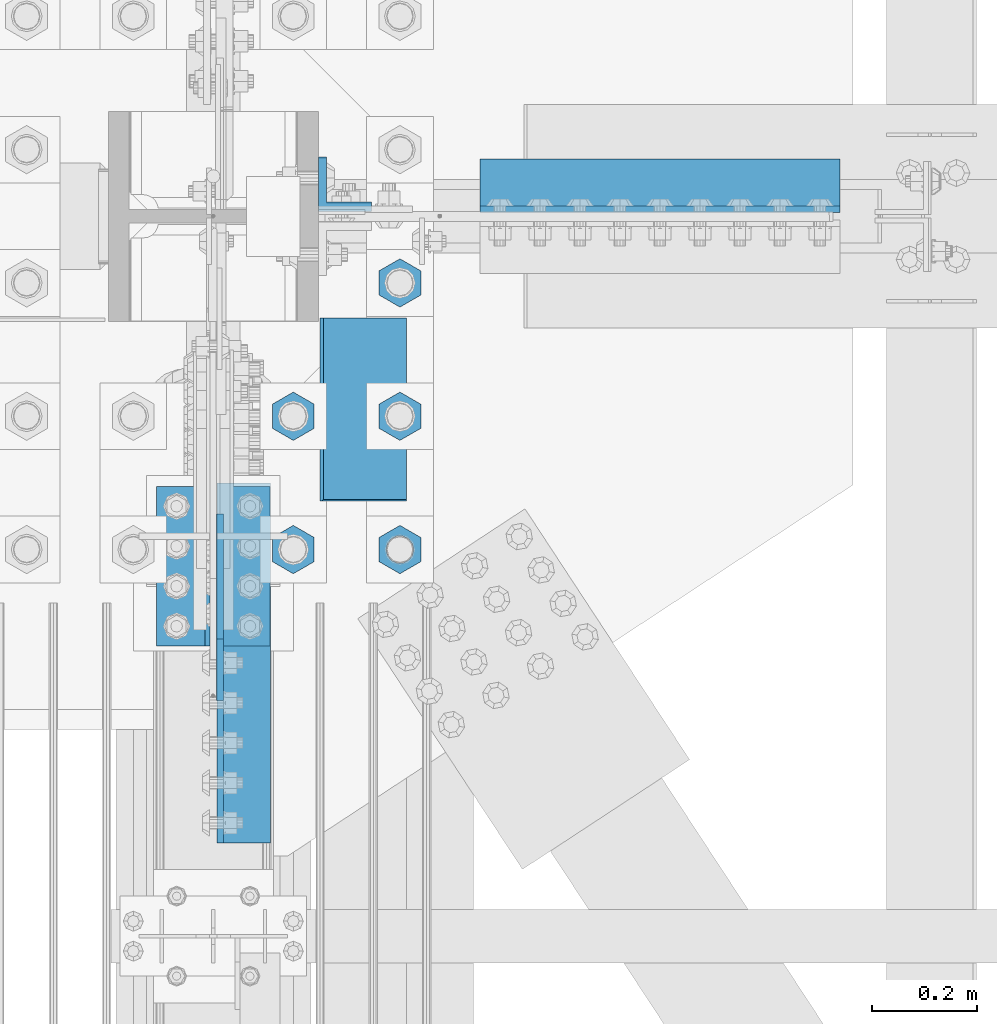
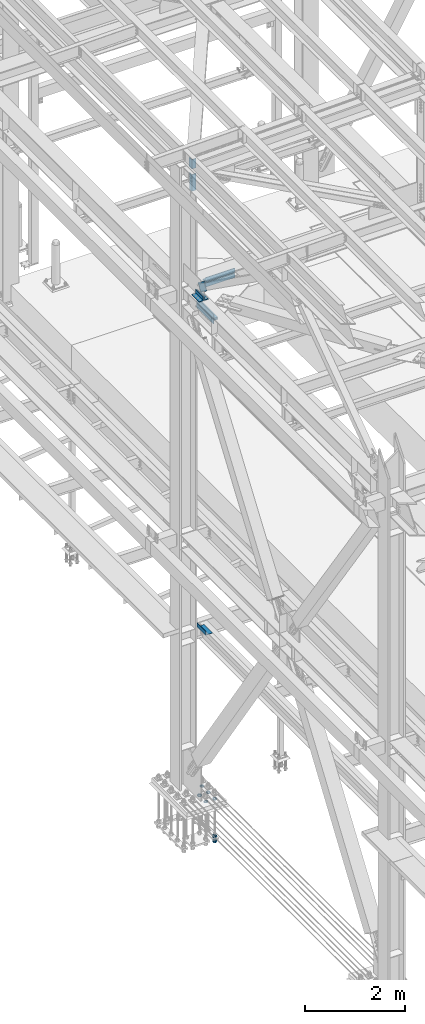
# One storey, part 2384 of 3843: 16 beams, 1 member, 8 elements without a shape of their own.
"""IFC2X3 building model written with IfcOpenShell, lengths in millimetres."""

import ifcopenshell
import ifcopenshell.guid

model = None  # the IFC model being written
_history = None  # IfcOwnerHistory: only IFC2X3 demands one
_inside = {}  # id of a spatial element -> (the spatial element, [elements in it])
_under = {}  # id of a project, library or spatial element -> (it, [spatial elements below it])
_declared = {}  # id of a project -> (the project, [libraries it declares])
_typed = {}  # id of a type object -> (the type object, [elements of that type])
_made_of = {}  # id of a material, layer set ... -> (it, [elements and type objects made of it])


def new_model(schema):
    """Start an empty IFC model of exactly this schema.

    Asked for "IFC4X3", IfcOpenShell would pick the latest addendum, in which some entities
    have other attributes; the version numbers below select the first issue.
    IFC2X3 requires an IfcOwnerHistory on every rooted entity: one is made here for all.
    """
    global model, _history
    if schema == "IFC4X3":
        model = ifcopenshell.file(schema_version=(4, 3, 0, 0))
    else:
        model = ifcopenshell.file(schema=schema)
    _inside.clear()
    _under.clear()
    _declared.clear()
    _typed.clear()
    _made_of.clear()
    _history = None
    if model.schema == "IFC2X3":
        org = make("IfcOrganization", Name="unknown")
        user = make(
            "IfcPersonAndOrganization",
            ThePerson=make("IfcPerson", FamilyName="unknown"),
            TheOrganization=org,
        )
        app = make(
            "IfcApplication",
            ApplicationDeveloper=org,
            Version="unknown",
            ApplicationFullName="unknown",
            ApplicationIdentifier="unknown",
        )
        _history = make(
            "IfcOwnerHistory",
            OwningUser=user,
            OwningApplication=app,
            ChangeAction="ADDED",
            CreationDate=0,
        )
    return model


def make(cls, **values):
    """One entity of the class cls with the attributes given. An attribute that is None is left unset."""
    return model.create_entity(
        cls, **{name: value for name, value in values.items() if value is not None}
    )


def rooted(cls, **values):
    """An entity with a GlobalId (a new one), such as an element, a storey or a relation."""
    return make(cls, GlobalId=ifcopenshell.guid.new(), OwnerHistory=_history, **values)


def si_unit(unit_type, name, prefix=None):
    """IfcSIUnit, for example si_unit("LENGTHUNIT", "METRE", prefix="MILLI")."""
    return make("IfcSIUnit", UnitType=unit_type, Prefix=prefix, Name=name)


def assignment(units):
    """IfcUnitAssignment: the units of a project."""
    return None if units is None else make("IfcUnitAssignment", Units=units)


def point(xyz):
    """IfcCartesianPoint."""
    return None if xyz is None else make("IfcCartesianPoint", Coordinates=xyz)


def direction(xyz):
    """IfcDirection."""
    return None if xyz is None else make("IfcDirection", DirectionRatios=xyz)


def frame(location, z_axis=None, x_axis=None):
    """IfcAxis2Placement3D, a coordinate frame: its origin and axes. An axis left out is left unset."""
    return make(
        "IfcAxis2Placement3D",
        Location=point(location),
        Axis=direction(z_axis),
        RefDirection=direction(x_axis),
    )


def origin_with_axes():
    """The frame at (0, 0, 0) with the z axis (0, 0, 1) and the x axis (1, 0, 0) written out."""
    return frame((0.0, 0.0, 0.0), z_axis=(0.0, 0.0, 1.0), x_axis=(1.0, 0.0, 0.0))


def place(relative_to, where):
    """IfcLocalPlacement: puts the frame where relative to a parent placement (None: the world)."""
    return make(
        "IfcLocalPlacement", PlacementRelTo=relative_to, RelativePlacement=where
    )


def context(
    kind, dimensions, precision=None, world=None, true_north=None, identifier=None
):
    """IfcGeometricRepresentationContext, for example the 3D "Model" context."""
    return make(
        "IfcGeometricRepresentationContext",
        ContextIdentifier=identifier,
        ContextType=kind,
        CoordinateSpaceDimension=dimensions,
        Precision=precision,
        WorldCoordinateSystem=world,
        TrueNorth=true_north,
    )


def subcontext(parent, identifier, kind, view, scale=None):
    """IfcGeometricRepresentationSubContext, for example "Body" below "Model"."""
    return make(
        "IfcGeometricRepresentationSubContext",
        ContextIdentifier=identifier,
        ContextType=kind,
        ParentContext=parent,
        TargetScale=scale,
        TargetView=view,
    )


def project(units=None, contexts=None):
    """IfcProject with its units and contexts."""
    return rooted(
        "IfcProject",
        Name="project",
        RepresentationContexts=contexts,
        UnitsInContext=assignment(units),
    )


def spatial(cls, under=None, at=None, **own):
    """A site, building, storey or space (cls), placed at a placement, below another one or the project."""
    s = rooted(cls, ObjectPlacement=at, **own)
    if under is not None:
        _under.setdefault(under.id(), (under, []))[1].append(s)
    return s


def faces_of(points, faces, orient=None, outer=None):
    """IfcFace entities. A face is a list of loops; a loop is a list of indices into points, from 0.

    orient and outer hold one flag for each loop. By default every Orientation is true, the
    first loop of a face is its IfcFaceOuterBound and the others are IfcFaceBound.
    """
    made = []
    for i, loops in enumerate(faces):
        bounds = []
        for j, loop in enumerate(loops):
            is_outer = j == 0 if outer is None else outer[i][j]
            bounds.append(
                make(
                    "IfcFaceOuterBound" if is_outer else "IfcFaceBound",
                    Bound=make("IfcPolyLoop", Polygon=[points[k] for k in loop]),
                    Orientation=True if orient is None else orient[i][j],
                )
            )
        made.append(make("IfcFace", Bounds=bounds))
    return made


def faceted_brep(points, faces, orient=None, outer=None, voids=None):
    """IfcFacetedBrep: a solid bounded by flat faces; with voids (closed shells), ...WithVoids."""
    shared = [point(p) for p in points]
    hull = make("IfcClosedShell", CfsFaces=faces_of(shared, faces, orient, outer))
    if voids is None:
        return make("IfcFacetedBrep", Outer=hull)
    return make(
        "IfcFacetedBrepWithVoids",
        Outer=hull,
        Voids=[
            make(cls, CfsFaces=faces_of(shared, fs, o, b)) for cls, fs, o, b in voids
        ],
    )


def shape(context_of_items, identifier, shape_type, items):
    """IfcShapeRepresentation: the items that make up one representation, for example the "Body"."""
    return make(
        "IfcShapeRepresentation",
        ContextOfItems=context_of_items,
        RepresentationIdentifier=identifier,
        RepresentationType=shape_type,
        Items=items,
    )


def material(Name=None, Category=None):
    """IfcMaterial."""
    return make("IfcMaterial", Name=Name, Category=Category)


def made_of(thing, what):
    """Note that an element or type object is made of a material, layer set ...; save() writes the relation."""
    if what is not None:
        _made_of.setdefault(what.id(), (what, []))[1].append(thing)
    return thing


def type_object(cls, material=None, **own):
    """A type object (cls), such as IfcWallType, which elements share."""
    return made_of(rooted(cls, **own), material)


def element(
    cls,
    number,
    at=None,
    inside=None,
    cuts=None,
    type_object=None,
    material=None,
    context=None,
    identifier="Body",
    shape_type=None,
    held_by="IfcProductDefinitionShape",
    body=None,
    shapes=None,
    **own,
):
    """One element of the class cls, such as IfcWall. Its Tag is "e" and its number.

    at: its placement. inside: the storey or other place that contains it. cuts: it is an
    opening in that element (IfcRelVoidsElement). A single representation is given by context,
    identifier, shape_type and body (its items); several are given by shapes. held_by: the class
    of the entity that holds the representations. save() writes the other relations.
    """
    e = rooted(cls, Tag="e%d" % number, ObjectPlacement=at, **own)
    if body is not None:
        shapes = [shape(context, identifier, shape_type, body)]
    if shapes is not None:
        e.Representation = make(held_by, Representations=shapes)
    if inside is not None:
        _inside.setdefault(inside.id(), (inside, []))[1].append(e)
    if cuts is not None:
        rooted(
            "IfcRelVoidsElement", RelatingBuildingElement=cuts, RelatedOpeningElement=e
        )
    if type_object is not None:
        _typed.setdefault(type_object.id(), (type_object, []))[1].append(e)
    return made_of(e, material)


def aggregate(whole, parts):
    """IfcRelAggregates: a whole, such as a stair, and the parts it consists of."""
    return rooted("IfcRelAggregates", RelatingObject=whole, RelatedObjects=parts)


def save(model, path):
    """Write the relations noted so far, then the file.

    IfcRelAggregates (storeys below a building ...), IfcRelContainedInSpatialStructure (elements
    in a storey), IfcRelDefinesByType, IfcRelAssociatesMaterial and IfcRelDeclares: one each for
    every whole, place, type object, material and project.
    """
    for whole, parts in _under.values():
        aggregate(whole, parts)
    for where, things in _inside.values():
        rooted(
            "IfcRelContainedInSpatialStructure",
            RelatedElements=things,
            RelatingStructure=where,
        )
    for kind, things in _typed.values():
        rooted("IfcRelDefinesByType", RelatedObjects=things, RelatingType=kind)
    for what, things in _made_of.values():
        rooted("IfcRelAssociatesMaterial", RelatedObjects=things, RelatingMaterial=what)
    for by, libraries in _declared.values():
        rooted("IfcRelDeclares", RelatingContext=by, RelatedDefinitions=libraries)
    model.write(path)


model = new_model("IFC2X3")

# Units and contexts
model_context = context("Model", 3, precision=1e-05, world=origin_with_axes())
body_context = subcontext(model_context, "Body", "Model", "MODEL_VIEW")
ifc_project = project(units=[si_unit("LENGTHUNIT", "METRE", prefix="MILLI"), si_unit("AREAUNIT", "SQUARE_METRE"), si_unit("VOLUMEUNIT", "CUBIC_METRE"), si_unit("MASSUNIT", "GRAM", prefix="KILO"), si_unit("TIMEUNIT", "SECOND"), si_unit("PLANEANGLEUNIT", "RADIAN"), si_unit("SOLIDANGLEUNIT", "STERADIAN"), si_unit("THERMODYNAMICTEMPERATUREUNIT", "DEGREE_CELSIUS"), si_unit("LUMINOUSINTENSITYUNIT", "LUMEN")], contexts=[model_context])

# Site, building, storey
site_placement = place(None, origin_with_axes())
site = spatial("IfcSite", under=ifc_project, at=site_placement, CompositionType="ELEMENT")
building_placement = place(site_placement, origin_with_axes())
building = spatial("IfcBuilding", under=site, at=building_placement, Name="Undefined", CompositionType="ELEMENT")
storey_placement = place(building_placement, origin_with_axes())
storey = spatial("IfcBuildingStorey", under=building, at=storey_placement, Name="Undefined", CompositionType="ELEMENT", Elevation=0.0)

# Assembly, beams
assembly_1_placement = place(storey_placement, origin_with_axes())
assembly_1 = element("IfcElementAssembly", 1, at=assembly_1_placement, inside=storey, Name="TEMPLATE", AssemblyPlace="NOTDEFINED", PredefinedType="RIGID_FRAME")
ifc_material_1 = material(Name="STEEL/A572-50")
beam_type_1 = type_object("IfcBeamType", Name="2_HALF_NUT", PredefinedType="NOTDEFINED")
beam_1_placement = place(assembly_1_placement, frame((36728.4, 74993.5, 30060.9), z_axis=(-1.0, 0.0, 0.0), x_axis=(0.0, 0.0, -1.0)))
beam_1 = element("IfcBeam", 2, at=beam_1_placement, type_object=beam_type_1, material=ifc_material_1, Name="NUT", ObjectType="2_HALF_NUT", context=body_context, shape_type="Brep", body=[
    faceted_brep([(0.0, -46.0369987487793, 0.0), (0.0, -23.0184993743896, -39.869213104248), (25.4000000000015, -23.0184993743896, -39.869213104248), (25.4000000000015, -46.0369987487793, 0.0), (0.0, 23.0184993743896, -39.869213104248), (25.4000000000015, 23.0184993743896, -39.869213104248), (0.0, 46.0369987487793, 0.0), (25.4000000000015, 46.0369987487793, 0.0), (0.0, 23.0184993743896, 39.869213104248), (25.4000000000015, 23.0184993743896, 39.869213104248), (0.0, -23.0184993743896, 39.869213104248), (25.4000000000015, -23.0184993743896, 39.869213104248), (0.0, 0.0, 26.1940002441406), (0.0, 11.3650617044477, 23.5999013092805), (25.4000000000015, 11.3650617044477, 23.5999013092805), (25.4000000000015, 0.0, 26.1940002441406), (0.0, 20.4791109456419, 16.3316083006721), (25.4000000000015, 20.4791109456419, 16.3316083006721), (0.0, 25.5370200498292, 5.82867859874386), (25.4000000000015, 25.5370200498292, 5.82867859874386), (0.0, 25.5370200498292, -5.82867859874386), (25.4000000000015, 25.5370200498292, -5.82867859874386), (0.0, 20.4791109456419, -16.3316083006721), (25.4000000000015, 20.4791109456419, -16.3316083006721), (0.0, 11.3650617044477, -23.5999013092805), (25.4000000000015, 11.3650617044477, -23.5999013092805), (0.0, 0.0, -26.1940002441406), (25.4000000000015, 0.0, -26.1940002441406), (0.0, -11.3650617044477, -23.5999013092805), (25.4000000000015, -11.3650617044477, -23.5999013092805), (0.0, -20.4791109456419, -16.3316083006721), (25.4000000000015, -20.4791109456419, -16.3316083006721), (0.0, -25.5370200498292, -5.82867859874386), (25.4000000000015, -25.5370200498292, -5.82867859874386), (0.0, -25.5370200498292, 5.82867859874386), (25.4000000000015, -25.5370200498292, 5.82867859874386), (0.0, -20.4791109456419, 16.3316083006721), (25.4000000000015, -20.4791109456419, 16.3316083006721), (0.0, -11.3650617044477, 23.5999013092805), (25.4000000000015, -11.3650617044477, 23.5999013092805)], [[[0, 1, 2, 3]], [[1, 4, 5, 2]], [[4, 6, 7, 5]], [[6, 8, 9, 7]], [[8, 10, 11, 9]], [[10, 0, 3, 11]], [[12, 13, 14, 15]], [[13, 16, 17, 14]], [[16, 18, 19, 17]], [[18, 20, 21, 19]], [[20, 22, 23, 21]], [[22, 24, 25, 23]], [[24, 26, 27, 25]], [[26, 28, 29, 27]], [[28, 30, 31, 29]], [[30, 32, 33, 31]], [[32, 34, 35, 33]], [[34, 36, 37, 35]], [[36, 38, 39, 37]], [[38, 12, 15, 39]], [[5, 7, 9, 11, 3, 2], [17, 19, 21, 23, 25, 27, 29, 31, 33, 35, 37, 39, 15, 14]], [[10, 8, 6, 4, 1, 0], [38, 36, 34, 32, 30, 28, 26, 24, 22, 20, 18, 16, 13, 12]]]),
])
beam_2_placement = place(assembly_1_placement, frame((36931.6, 74993.5, 30060.9), z_axis=(-1.0, 0.0, 0.0), x_axis=(0.0, 0.0, -1.0)))
beam_2 = element("IfcBeam", 3, at=beam_2_placement, type_object=beam_type_1, material=ifc_material_1, Name="NUT", ObjectType="2_HALF_NUT", context=body_context, shape_type="Brep", body=[
    faceted_brep([(0.0, -46.0369987487793, 0.0), (0.0, -23.0184993743896, -39.869213104248), (25.4000000000015, -23.0184993743896, -39.869213104248), (25.4000000000015, -46.0369987487793, 0.0), (0.0, 23.0184993743896, -39.869213104248), (25.4000000000015, 23.0184993743896, -39.869213104248), (0.0, 46.0369987487793, 0.0), (25.4000000000015, 46.0369987487793, 0.0), (0.0, 23.0184993743896, 39.869213104248), (25.4000000000015, 23.0184993743896, 39.869213104248), (0.0, -23.0184993743896, 39.869213104248), (25.4000000000015, -23.0184993743896, 39.869213104248), (0.0, 0.0, 26.1940002441406), (0.0, 11.3650617044477, 23.5999013092805), (25.4000000000015, 11.3650617044477, 23.5999013092805), (25.4000000000015, 0.0, 26.1940002441406), (0.0, 20.4791109456419, 16.3316083006721), (25.4000000000015, 20.4791109456419, 16.3316083006721), (0.0, 25.5370200498292, 5.82867859874386), (25.4000000000015, 25.5370200498292, 5.82867859874386), (0.0, 25.5370200498292, -5.82867859874386), (25.4000000000015, 25.5370200498292, -5.82867859874386), (0.0, 20.4791109456419, -16.3316083006721), (25.4000000000015, 20.4791109456419, -16.3316083006721), (0.0, 11.3650617044477, -23.5999013092805), (25.4000000000015, 11.3650617044477, -23.5999013092805), (0.0, 0.0, -26.1940002441406), (25.4000000000015, 0.0, -26.1940002441406), (0.0, -11.3650617044477, -23.5999013092805), (25.4000000000015, -11.3650617044477, -23.5999013092805), (0.0, -20.4791109456419, -16.3316083006721), (25.4000000000015, -20.4791109456419, -16.3316083006721), (0.0, -25.5370200498292, -5.82867859874386), (25.4000000000015, -25.5370200498292, -5.82867859874386), (0.0, -25.5370200498292, 5.82867859874386), (25.4000000000015, -25.5370200498292, 5.82867859874386), (0.0, -20.4791109456419, 16.3316083006721), (25.4000000000015, -20.4791109456419, 16.3316083006721), (0.0, -11.3650617044477, 23.5999013092805), (25.4000000000015, -11.3650617044477, 23.5999013092805)], [[[0, 1, 2, 3]], [[1, 4, 5, 2]], [[4, 6, 7, 5]], [[6, 8, 9, 7]], [[8, 10, 11, 9]], [[10, 0, 3, 11]], [[12, 13, 14, 15]], [[13, 16, 17, 14]], [[16, 18, 19, 17]], [[18, 20, 21, 19]], [[20, 22, 23, 21]], [[22, 24, 25, 23]], [[24, 26, 27, 25]], [[26, 28, 29, 27]], [[28, 30, 31, 29]], [[30, 32, 33, 31]], [[32, 34, 35, 33]], [[34, 36, 37, 35]], [[36, 38, 39, 37]], [[38, 12, 15, 39]], [[5, 7, 9, 11, 3, 2], [17, 19, 21, 23, 25, 27, 29, 31, 33, 35, 37, 39, 15, 14]], [[10, 8, 6, 4, 1, 0], [38, 36, 34, 32, 30, 28, 26, 24, 22, 20, 18, 16, 13, 12]]]),
])
beam_3_placement = place(assembly_1_placement, frame((36931.6, 75247.5, 30060.9), z_axis=(-1.0, 0.0, 0.0), x_axis=(0.0, 0.0, -1.0)))
beam_3 = element("IfcBeam", 4, at=beam_3_placement, type_object=beam_type_1, material=ifc_material_1, Name="NUT", ObjectType="2_HALF_NUT", context=body_context, shape_type="Brep", body=[
    faceted_brep([(0.0, -46.0369987487793, 0.0), (0.0, -23.0184993743896, -39.869213104248), (25.4000000000015, -23.0184993743896, -39.869213104248), (25.4000000000015, -46.0369987487793, 0.0), (0.0, 23.0184993743896, -39.869213104248), (25.4000000000015, 23.0184993743896, -39.869213104248), (0.0, 46.0369987487793, 0.0), (25.4000000000015, 46.0369987487793, 0.0), (0.0, 23.0184993743896, 39.869213104248), (25.4000000000015, 23.0184993743896, 39.869213104248), (0.0, -23.0184993743896, 39.869213104248), (25.4000000000015, -23.0184993743896, 39.869213104248), (0.0, 0.0, 26.1940002441406), (0.0, 11.3650617044477, 23.5999013092805), (25.4000000000015, 11.3650617044477, 23.5999013092805), (25.4000000000015, 0.0, 26.1940002441406), (0.0, 20.4791109456419, 16.3316083006721), (25.4000000000015, 20.4791109456419, 16.3316083006721), (0.0, 25.5370200498292, 5.82867859874386), (25.4000000000015, 25.5370200498292, 5.82867859874386), (0.0, 25.5370200498292, -5.82867859874386), (25.4000000000015, 25.5370200498292, -5.82867859874386), (0.0, 20.4791109456419, -16.3316083006721), (25.4000000000015, 20.4791109456419, -16.3316083006721), (0.0, 11.3650617044477, -23.5999013092805), (25.4000000000015, 11.3650617044477, -23.5999013092805), (0.0, 0.0, -26.1940002441406), (25.4000000000015, 0.0, -26.1940002441406), (0.0, -11.3650617044477, -23.5999013092805), (25.4000000000015, -11.3650617044477, -23.5999013092805), (0.0, -20.4791109456419, -16.3316083006721), (25.4000000000015, -20.4791109456419, -16.3316083006721), (0.0, -25.5370200498292, -5.82867859874386), (25.4000000000015, -25.5370200498292, -5.82867859874386), (0.0, -25.5370200498292, 5.82867859874386), (25.4000000000015, -25.5370200498292, 5.82867859874386), (0.0, -20.4791109456419, 16.3316083006721), (25.4000000000015, -20.4791109456419, 16.3316083006721), (0.0, -11.3650617044477, 23.5999013092805), (25.4000000000015, -11.3650617044477, 23.5999013092805)], [[[0, 1, 2, 3]], [[1, 4, 5, 2]], [[4, 6, 7, 5]], [[6, 8, 9, 7]], [[8, 10, 11, 9]], [[10, 0, 3, 11]], [[12, 13, 14, 15]], [[13, 16, 17, 14]], [[16, 18, 19, 17]], [[18, 20, 21, 19]], [[20, 22, 23, 21]], [[22, 24, 25, 23]], [[24, 26, 27, 25]], [[26, 28, 29, 27]], [[28, 30, 31, 29]], [[30, 32, 33, 31]], [[32, 34, 35, 33]], [[34, 36, 37, 35]], [[36, 38, 39, 37]], [[38, 12, 15, 39]], [[5, 7, 9, 11, 3, 2], [17, 19, 21, 23, 25, 27, 29, 31, 33, 35, 37, 39, 15, 14]], [[10, 8, 6, 4, 1, 0], [38, 36, 34, 32, 30, 28, 26, 24, 22, 20, 18, 16, 13, 12]]]),
])
beam_4_placement = place(assembly_1_placement, frame((36728.4, 75247.5, 30060.9), z_axis=(-1.0, 0.0, 0.0), x_axis=(0.0, 0.0, -1.0)))
beam_4 = element("IfcBeam", 5, at=beam_4_placement, type_object=beam_type_1, material=ifc_material_1, Name="NUT", ObjectType="2_HALF_NUT", context=body_context, shape_type="Brep", body=[
    faceted_brep([(0.0, -46.0369987487793, 0.0), (0.0, -23.0184993743896, -39.869213104248), (25.4000000000015, -23.0184993743896, -39.869213104248), (25.4000000000015, -46.0369987487793, 0.0), (0.0, 23.0184993743896, -39.869213104248), (25.4000000000015, 23.0184993743896, -39.869213104248), (0.0, 46.0369987487793, 0.0), (25.4000000000015, 46.0369987487793, 0.0), (0.0, 23.0184993743896, 39.869213104248), (25.4000000000015, 23.0184993743896, 39.869213104248), (0.0, -23.0184993743896, 39.869213104248), (25.4000000000015, -23.0184993743896, 39.869213104248), (0.0, 0.0, 26.1940002441406), (0.0, 11.3650617044477, 23.5999013092805), (25.4000000000015, 11.3650617044477, 23.5999013092805), (25.4000000000015, 0.0, 26.1940002441406), (0.0, 20.4791109456419, 16.3316083006721), (25.4000000000015, 20.4791109456419, 16.3316083006721), (0.0, 25.5370200498292, 5.82867859874386), (25.4000000000015, 25.5370200498292, 5.82867859874386), (0.0, 25.5370200498292, -5.82867859874386), (25.4000000000015, 25.5370200498292, -5.82867859874386), (0.0, 20.4791109456419, -16.3316083006721), (25.4000000000015, 20.4791109456419, -16.3316083006721), (0.0, 11.3650617044477, -23.5999013092805), (25.4000000000015, 11.3650617044477, -23.5999013092805), (0.0, 0.0, -26.1940002441406), (25.4000000000015, 0.0, -26.1940002441406), (0.0, -11.3650617044477, -23.5999013092805), (25.4000000000015, -11.3650617044477, -23.5999013092805), (0.0, -20.4791109456419, -16.3316083006721), (25.4000000000015, -20.4791109456419, -16.3316083006721), (0.0, -25.5370200498292, -5.82867859874386), (25.4000000000015, -25.5370200498292, -5.82867859874386), (0.0, -25.5370200498292, 5.82867859874386), (25.4000000000015, -25.5370200498292, 5.82867859874386), (0.0, -20.4791109456419, 16.3316083006721), (25.4000000000015, -20.4791109456419, 16.3316083006721), (0.0, -11.3650617044477, 23.5999013092805), (25.4000000000015, -11.3650617044477, 23.5999013092805)], [[[0, 1, 2, 3]], [[1, 4, 5, 2]], [[4, 6, 7, 5]], [[6, 8, 9, 7]], [[8, 10, 11, 9]], [[10, 0, 3, 11]], [[12, 13, 14, 15]], [[13, 16, 17, 14]], [[16, 18, 19, 17]], [[18, 20, 21, 19]], [[20, 22, 23, 21]], [[22, 24, 25, 23]], [[24, 26, 27, 25]], [[26, 28, 29, 27]], [[28, 30, 31, 29]], [[30, 32, 33, 31]], [[32, 34, 35, 33]], [[34, 36, 37, 35]], [[36, 38, 39, 37]], [[38, 12, 15, 39]], [[5, 7, 9, 11, 3, 2], [17, 19, 21, 23, 25, 27, 29, 31, 33, 35, 37, 39, 15, 14]], [[10, 8, 6, 4, 1, 0], [38, 36, 34, 32, 30, 28, 26, 24, 22, 20, 18, 16, 13, 12]]]),
])
beam_5_placement = place(assembly_1_placement, frame((36931.6, 75501.5, 30060.9), z_axis=(-1.0, 0.0, 0.0), x_axis=(0.0, 0.0, -1.0)))
beam_5 = element("IfcBeam", 6, at=beam_5_placement, type_object=beam_type_1, material=ifc_material_1, Name="NUT", ObjectType="2_HALF_NUT", context=body_context, shape_type="Brep", body=[
    faceted_brep([(0.0, -46.0369987487793, 0.0), (0.0, -23.0184993743896, -39.869213104248), (25.4000000000015, -23.0184993743896, -39.869213104248), (25.4000000000015, -46.0369987487793, 0.0), (0.0, 23.0184993743896, -39.869213104248), (25.4000000000015, 23.0184993743896, -39.869213104248), (0.0, 46.0369987487793, 0.0), (25.4000000000015, 46.0369987487793, 0.0), (0.0, 23.0184993743896, 39.869213104248), (25.4000000000015, 23.0184993743896, 39.869213104248), (0.0, -23.0184993743896, 39.869213104248), (25.4000000000015, -23.0184993743896, 39.869213104248), (0.0, 0.0, 26.1940002441406), (0.0, 11.3650617044477, 23.5999013092805), (25.4000000000015, 11.3650617044477, 23.5999013092805), (25.4000000000015, 0.0, 26.1940002441406), (0.0, 20.4791109456419, 16.3316083006721), (25.4000000000015, 20.4791109456419, 16.3316083006721), (0.0, 25.5370200498292, 5.82867859874386), (25.4000000000015, 25.5370200498292, 5.82867859874386), (0.0, 25.5370200498292, -5.82867859874386), (25.4000000000015, 25.5370200498292, -5.82867859874386), (0.0, 20.4791109456419, -16.3316083006721), (25.4000000000015, 20.4791109456419, -16.3316083006721), (0.0, 11.3650617044477, -23.5999013092805), (25.4000000000015, 11.3650617044477, -23.5999013092805), (0.0, 0.0, -26.1940002441406), (25.4000000000015, 0.0, -26.1940002441406), (0.0, -11.3650617044477, -23.5999013092805), (25.4000000000015, -11.3650617044477, -23.5999013092805), (0.0, -20.4791109456419, -16.3316083006721), (25.4000000000015, -20.4791109456419, -16.3316083006721), (0.0, -25.5370200498292, -5.82867859874386), (25.4000000000015, -25.5370200498292, -5.82867859874386), (0.0, -25.5370200498292, 5.82867859874386), (25.4000000000015, -25.5370200498292, 5.82867859874386), (0.0, -20.4791109456419, 16.3316083006721), (25.4000000000015, -20.4791109456419, 16.3316083006721), (0.0, -11.3650617044477, 23.5999013092805), (25.4000000000015, -11.3650617044477, 23.5999013092805)], [[[0, 1, 2, 3]], [[1, 4, 5, 2]], [[4, 6, 7, 5]], [[6, 8, 9, 7]], [[8, 10, 11, 9]], [[10, 0, 3, 11]], [[12, 13, 14, 15]], [[13, 16, 17, 14]], [[16, 18, 19, 17]], [[18, 20, 21, 19]], [[20, 22, 23, 21]], [[22, 24, 25, 23]], [[24, 26, 27, 25]], [[26, 28, 29, 27]], [[28, 30, 31, 29]], [[30, 32, 33, 31]], [[32, 34, 35, 33]], [[34, 36, 37, 35]], [[36, 38, 39, 37]], [[38, 12, 15, 39]], [[5, 7, 9, 11, 3, 2], [17, 19, 21, 23, 25, 27, 29, 31, 33, 35, 37, 39, 15, 14]], [[10, 8, 6, 4, 1, 0], [38, 36, 34, 32, 30, 28, 26, 24, 22, 20, 18, 16, 13, 12]]]),
])
beam_type_2 = type_object("IfcBeamType", Name="2_HEAVY_HEX_NUT", PredefinedType="NOTDEFINED")
beam_6_placement = place(assembly_1_placement, frame((36931.6, 74993.5, 29159.2), z_axis=(-1.0, 0.0, 0.0), x_axis=(0.0, 0.0, -1.0)))
beam_6 = element("IfcBeam", 7, at=beam_6_placement, type_object=beam_type_2, material=ifc_material_1, Name="NUT", ObjectType="2_HEAVY_HEX_NUT", context=body_context, shape_type="Brep", body=[
    faceted_brep([(0.0, -46.0369987487793, 0.0), (0.0, -23.0184993743896, -39.869213104248), (50.7999999999993, -23.0184993743896, -39.869213104248), (50.7999999999993, -46.0369987487793, 0.0), (0.0, 23.0184993743896, -39.869213104248), (50.7999999999993, 23.0184993743896, -39.869213104248), (0.0, 46.0369987487793, 0.0), (50.7999999999993, 46.0369987487793, 0.0), (0.0, 23.0184993743896, 39.869213104248), (50.7999999999993, 23.0184993743896, 39.869213104248), (0.0, -23.0184993743896, 39.869213104248), (50.7999999999993, -23.0184993743896, 39.869213104248), (0.0, 0.0, 26.1940002441406), (0.0, 11.3650617044477, 23.5999013092805), (50.7999999999993, 11.3650617044477, 23.5999013092805), (50.7999999999993, 0.0, 26.1940002441406), (0.0, 20.4791109456419, 16.3316083006721), (50.7999999999993, 20.4791109456419, 16.3316083006721), (0.0, 25.5370200498292, 5.82867859874386), (50.7999999999993, 25.5370200498292, 5.82867859874386), (0.0, 25.5370200498292, -5.82867859874386), (50.7999999999993, 25.5370200498292, -5.82867859874386), (0.0, 20.4791109456419, -16.3316083006721), (50.7999999999993, 20.4791109456419, -16.3316083006721), (0.0, 11.3650617044477, -23.5999013092805), (50.7999999999993, 11.3650617044477, -23.5999013092805), (0.0, 0.0, -26.1940002441406), (50.7999999999993, 0.0, -26.1940002441406), (0.0, -11.3650617044477, -23.5999013092805), (50.7999999999993, -11.3650617044477, -23.5999013092805), (0.0, -20.4791109456419, -16.3316083006721), (50.7999999999993, -20.4791109456419, -16.3316083006721), (0.0, -25.5370200498292, -5.82867859874386), (50.7999999999993, -25.5370200498292, -5.82867859874386), (0.0, -25.5370200498292, 5.82867859874386), (50.7999999999993, -25.5370200498292, 5.82867859874386), (0.0, -20.4791109456419, 16.3316083006721), (50.7999999999993, -20.4791109456419, 16.3316083006721), (0.0, -11.3650617044477, 23.5999013092805), (50.7999999999993, -11.3650617044477, 23.5999013092805)], [[[0, 1, 2, 3]], [[1, 4, 5, 2]], [[4, 6, 7, 5]], [[6, 8, 9, 7]], [[8, 10, 11, 9]], [[10, 0, 3, 11]], [[12, 13, 14, 15]], [[13, 16, 17, 14]], [[16, 18, 19, 17]], [[18, 20, 21, 19]], [[20, 22, 23, 21]], [[22, 24, 25, 23]], [[24, 26, 27, 25]], [[26, 28, 29, 27]], [[28, 30, 31, 29]], [[30, 32, 33, 31]], [[32, 34, 35, 33]], [[34, 36, 37, 35]], [[36, 38, 39, 37]], [[38, 12, 15, 39]], [[5, 7, 9, 11, 3, 2], [17, 19, 21, 23, 25, 27, 29, 31, 33, 35, 37, 39, 15, 14]], [[10, 8, 6, 4, 1, 0], [38, 36, 34, 32, 30, 28, 26, 24, 22, 20, 18, 16, 13, 12]]]),
])
beam_7_placement = place(assembly_1_placement, frame((36931.6, 74993.5, 29044.9), z_axis=(1.0, 0.0, 0.0), x_axis=(0.0, 0.0, -1.0)))
beam_7 = element("IfcBeam", 8, at=beam_7_placement, type_object=beam_type_2, material=ifc_material_1, Name="NUT", ObjectType="2_HEAVY_HEX_NUT", context=body_context, shape_type="Brep", body=[
    faceted_brep([(0.0, -46.0369987487793, 0.0), (0.0, -23.0184993743896, -39.869213104248), (50.7999999999993, -23.0184993743896, -39.869213104248), (50.7999999999993, -46.0369987487793, 0.0), (0.0, 23.0184993743896, -39.869213104248), (50.7999999999993, 23.0184993743896, -39.869213104248), (0.0, 46.0369987487793, 0.0), (50.7999999999993, 46.0369987487793, 0.0), (0.0, 23.0184993743896, 39.869213104248), (50.7999999999993, 23.0184993743896, 39.869213104248), (0.0, -23.0184993743896, 39.869213104248), (50.7999999999993, -23.0184993743896, 39.869213104248), (0.0, 0.0, 26.1940002441406), (0.0, 11.3650617044477, 23.5999013092805), (50.7999999999993, 11.3650617044477, 23.5999013092805), (50.7999999999993, 0.0, 26.1940002441406), (0.0, 20.4791109456419, 16.3316083006721), (50.7999999999993, 20.4791109456419, 16.3316083006721), (0.0, 25.5370200498292, 5.82867859874386), (50.7999999999993, 25.5370200498292, 5.82867859874386), (0.0, 25.5370200498292, -5.82867859874386), (50.7999999999993, 25.5370200498292, -5.82867859874386), (0.0, 20.4791109456419, -16.3316083006721), (50.7999999999993, 20.4791109456419, -16.3316083006721), (0.0, 11.3650617044477, -23.5999013092805), (50.7999999999993, 11.3650617044477, -23.5999013092805), (0.0, 0.0, -26.1940002441406), (50.7999999999993, 0.0, -26.1940002441406), (0.0, -11.3650617044477, -23.5999013092805), (50.7999999999993, -11.3650617044477, -23.5999013092805), (0.0, -20.4791109456419, -16.3316083006721), (50.7999999999993, -20.4791109456419, -16.3316083006721), (0.0, -25.5370200498292, -5.82867859874386), (50.7999999999993, -25.5370200498292, -5.82867859874386), (0.0, -25.5370200498292, 5.82867859874386), (50.7999999999993, -25.5370200498292, 5.82867859874386), (0.0, -20.4791109456419, 16.3316083006721), (50.7999999999993, -20.4791109456419, 16.3316083006721), (0.0, -11.3650617044477, 23.5999013092805), (50.7999999999993, -11.3650617044477, 23.5999013092805)], [[[0, 1, 2, 3]], [[1, 4, 5, 2]], [[4, 6, 7, 5]], [[6, 8, 9, 7]], [[8, 10, 11, 9]], [[10, 0, 3, 11]], [[12, 13, 14, 15]], [[13, 16, 17, 14]], [[16, 18, 19, 17]], [[18, 20, 21, 19]], [[20, 22, 23, 21]], [[22, 24, 25, 23]], [[24, 26, 27, 25]], [[26, 28, 29, 27]], [[28, 30, 31, 29]], [[30, 32, 33, 31]], [[32, 34, 35, 33]], [[34, 36, 37, 35]], [[36, 38, 39, 37]], [[38, 12, 15, 39]], [[5, 7, 9, 11, 3, 2], [17, 19, 21, 23, 25, 27, 29, 31, 33, 35, 37, 39, 15, 14]], [[10, 8, 6, 4, 1, 0], [38, 36, 34, 32, 30, 28, 26, 24, 22, 20, 18, 16, 13, 12]]]),
])
aggregate(assembly_1, [beam_6, beam_1, beam_2, beam_3, beam_4, beam_5, beam_7])

# Assembly, beam
assembly_2_placement = place(storey_placement, origin_with_axes())
assembly_2 = element("IfcElementAssembly", 9, at=assembly_2_placement, inside=storey, Name="ANGLE", AssemblyPlace="NOTDEFINED", PredefinedType="RIGID_FRAME")
beam_type_3 = type_object("IfcBeamType", Name="L4X4X3/8", PredefinedType="NOTDEFINED")
beam_8_placement = place(assembly_2_placement, frame((36633.1499999316, 74809.3500000095, 42519.5999999836), z_axis=(0.0, 0.0, 1.0), x_axis=(0.0, 1.0, 0.0)))
beam_8 = element("IfcBeam", 10, at=beam_8_placement, type_object=beam_type_3, material=ifc_material_1, Name="ANGLE", ObjectType="L4X4X3/8", context=body_context, shape_type="Brep", body=[
    faceted_brep([(0.0, 50.8000000000029, -50.8000000000029), (0.0, 50.8000000000029, 50.8000000000029), (304.800000000003, 50.8000000000029, 50.8000000000029), (304.800000000003, 50.8000000000029, -50.8000000000029), (0.0, 41.2750000000015, 50.8000000000029), (304.800000000003, 41.2749999999942, 50.8000000000029), (0.0, 41.2749999999942, -41.2750000000015), (304.800000000003, 41.2749999999942, -41.2750000000015), (0.0, -50.8000000000029, -41.2750000000015), (304.800000000003, -50.8000000000029, -41.2750000000015), (0.0, -50.8000000000029, -50.8000000000029), (304.800000000003, -50.8000000000029, -50.8000000000029)], [[[0, 1, 2, 3]], [[1, 4, 5, 2]], [[4, 6, 7, 5]], [[6, 8, 9, 7]], [[8, 10, 11, 9]], [[10, 0, 3, 11]], [[5, 7, 9, 11, 3, 2]], [[10, 8, 6, 4, 1, 0]]]),
])
aggregate(assembly_2, [beam_8])

assembly_3_placement = place(storey_placement, origin_with_axes())
assembly_3 = element("IfcElementAssembly", 11, at=assembly_3_placement, inside=storey, Name="ANGLE", AssemblyPlace="NOTDEFINED", PredefinedType="RIGID_FRAME")
beam_9_placement = place(assembly_3_placement, frame((36518.8499999316, 75114.1500000095, 42519.5999999836), z_axis=(0.0, 0.0, 1.0), x_axis=(0.0, -1.0, 0.0)))
beam_9 = element("IfcBeam", 12, at=beam_9_placement, type_object=beam_type_3, material=ifc_material_1, Name="ANGLE", ObjectType="L4X4X3/8", context=body_context, shape_type="Brep", body=[
    faceted_brep([(0.0, 50.8000000000029, -50.8000000000029), (0.0, 50.8000000000029, 50.8000000000029), (304.800000000003, 50.8000000000029, 50.8000000000029), (304.800000000003, 50.8000000000029, -50.8000000000029), (0.0, 41.2750000000015, 50.8000000000029), (304.800000000003, 41.2749999999942, 50.8000000000029), (0.0, 41.2749999999942, -41.2750000000015), (304.800000000003, 41.2749999999942, -41.2750000000015), (0.0, -50.8000000000029, -41.2750000000015), (304.800000000003, -50.8000000000029, -41.2750000000015), (0.0, -50.8000000000029, -50.8000000000029), (304.800000000003, -50.8000000000029, -50.8000000000029)], [[[0, 1, 2, 3]], [[1, 4, 5, 2]], [[4, 6, 7, 5]], [[6, 8, 9, 7]], [[8, 10, 11, 9]], [[10, 0, 3, 11]], [[5, 7, 9, 11, 3, 2]], [[10, 8, 6, 4, 1, 0]]]),
])
aggregate(assembly_3, [beam_9])

assembly_4_placement = place(storey_placement, origin_with_axes())
assembly_4 = element("IfcElementAssembly", 13, at=assembly_4_placement, inside=storey, Name="BEAM", AssemblyPlace="NOTDEFINED", PredefinedType="RIGID_FRAME")
ifc_material_2 = material(Name="STEEL/A36")
beam_type_4 = type_object("IfcBeamType", PredefinedType="NOTDEFINED")
beam_10_placement = place(assembly_4_placement, frame((36944.3, 75260.2, 34039.175), z_axis=(0.0, -1.0, 0.0), x_axis=(-1.0, 0.0, 0.0)))
beam_10 = element("IfcBeam", 14, at=beam_10_placement, type_object=beam_type_4, material=ifc_material_2, Name="BENT_PLATE", context=body_context, shape_type="Brep", body=[
    faceted_brep([(158.750000000022, -98.4249999999665, 171.450000047684), (161.924999952338, -98.4249999999665, 174.625), (161.924999952338, -4.76647983305156e-08, 174.625), (158.750000000022, -3.17500000000291, 171.450000047684), (0.0, -4.76647983305156e-08, 174.625), (0.0, -3.17500000000291, 171.450000047655), (0.0, -3.17500000000291, -174.625), (158.750000000022, -3.17500000000291, -174.625), (0.0, 3.17500000000291, 174.625), (0.0, 3.17500000000291, -174.625), (165.100000000028, 3.17500000000291, 174.625), (165.100000000028, 3.17500000000291, -174.625), (165.100000000028, -98.4249999999665, 174.625), (165.100000000028, -98.4249999999665, -174.625), (158.750000000022, -98.4249999999665, -174.625)], [[[0, 1, 2, 3]], [[3, 2, 4, 5]], [[6, 7, 3, 5]], [[8, 9, 6, 5, 4]], [[9, 8, 10, 11]], [[11, 10, 12, 13]], [[1, 12, 10, 8, 4, 2]], [[7, 14, 0, 3]], [[7, 6, 9, 11, 13, 14]], [[14, 13, 12, 1, 0]]]),
])
aggregate(assembly_4, [beam_10])

# Assembly, beams
assembly_5_placement = place(storey_placement, origin_with_axes())
assembly_5 = element("IfcElementAssembly", 15, at=assembly_5_placement, inside=storey, Name="PLATE", AssemblyPlace="NOTDEFINED", PredefinedType="RIGID_FRAME")
beam_type_5 = type_object("IfcBeamType", Name="L4X4X1/2", PredefinedType="NOTDEFINED")
beam_11_placement = place(assembly_5_placement, frame((37084.0, 75686.4437499962, 42297.351628647), z_axis=(0.0, 1.0, 0.0), x_axis=(1.0, 0.0, 0.0)))
beam_11 = element("IfcBeam", 16, at=beam_11_placement, type_object=beam_type_5, material=ifc_material_1, Name="ANGLE", ObjectType="L4X4X1/2", context=body_context, shape_type="Brep", body=[
    faceted_brep([(0.0, 50.8000000000029, -50.8000000000029), (0.0, 50.8000000000029, 50.8000000000029), (685.800000000003, 50.8000000000029, 50.8000000000029), (685.800000000003, 50.8000000000029, -50.8000000000029), (0.0, 38.0999999999985, 50.8000000000029), (685.800000000003, 38.0999999999985, 50.8000000000029), (0.0, 38.0999999999985, -38.0999999999985), (685.800000000003, 38.0999999999985, -38.1000000000058), (0.0, -50.8000000000029, -38.1000000000058), (685.800000000003, -50.8000000000029, -38.1000000000058), (0.0, -50.8000000000029, -50.8000000000029), (685.800000000003, -50.8000000000029, -50.8000000000029)], [[[0, 1, 2, 3]], [[1, 4, 5, 2]], [[4, 6, 7, 5]], [[6, 8, 9, 7]], [[8, 10, 11, 9]], [[10, 0, 3, 11]], [[5, 7, 9, 11, 3, 2]], [[10, 8, 6, 4, 1, 0]]]),
])
beam_12_placement = place(assembly_5_placement, frame((37769.8, 75686.4437499962, 42167.1766278841), z_axis=(0.0, 1.0, 0.0), x_axis=(-1.0, 0.0, 0.0)))
beam_12 = element("IfcBeam", 17, at=beam_12_placement, type_object=beam_type_5, material=ifc_material_1, Name="ANGLE", ObjectType="L4X4X1/2", context=body_context, shape_type="Brep", body=[
    faceted_brep([(0.0, 50.8000000000029, -50.8000000000029), (0.0, 50.8000000000029, 50.8000000000029), (685.800000000003, 50.8000000000029, 50.8000000000029), (685.800000000003, 50.8000000000029, -50.8000000000029), (0.0, 38.0999999999985, 50.8000000000029), (685.800000000003, 38.0999999999985, 50.8000000000029), (0.0, 38.0999999999985, -38.0999999999985), (685.800000000003, 38.0999999999985, -38.1000000000058), (0.0, -50.8000000000029, -38.1000000000058), (685.800000000003, -50.8000000000029, -38.1000000000058), (0.0, -50.8000000000029, -50.8000000000029), (685.800000000003, -50.8000000000029, -50.8000000000029)], [[[0, 1, 2, 3]], [[1, 4, 5, 2]], [[4, 6, 7, 5]], [[6, 8, 9, 7]], [[8, 10, 11, 9]], [[10, 0, 3, 11]], [[5, 7, 9, 11, 3, 2]], [[10, 8, 6, 4, 1, 0]]]),
])
aggregate(assembly_5, [beam_11, beam_12])

assembly_6_placement = place(storey_placement, origin_with_axes())
assembly_6 = element("IfcElementAssembly", 18, at=assembly_6_placement, inside=storey, Name="PLATE", AssemblyPlace="NOTDEFINED", PredefinedType="RIGID_FRAME")
beam_13_placement = place(assembly_6_placement, frame((36633.9437500007, 75120.5, 42297.351628647), z_axis=(1.0, 0.0, 0.0), x_axis=(0.0, -1.0, 0.0)))
beam_13 = element("IfcBeam", 19, at=beam_13_placement, type_object=beam_type_5, material=ifc_material_1, Name="ANGLE", ObjectType="L4X4X1/2", context=body_context, shape_type="Brep", body=[
    faceted_brep([(0.0, 50.8000000000029, -50.8000000000029), (0.0, 50.8000000000029, 50.8000000000029), (685.800000000003, 50.8000000000029, 50.8000000000029), (685.800000000003, 50.8000000000029, -50.8000000000029), (0.0, 38.0999999999985, 50.8000000000029), (685.800000000003, 38.0999999999985, 50.8000000000029), (0.0, 38.0999999999985, -38.0999999999985), (685.800000000003, 38.0999999999985, -38.1000000000058), (0.0, -50.8000000000029, -38.1000000000058), (685.800000000003, -50.8000000000029, -38.1000000000058), (0.0, -50.8000000000029, -50.8000000000029), (685.800000000003, -50.8000000000029, -50.8000000000029)], [[[0, 1, 2, 3]], [[1, 4, 5, 2]], [[4, 6, 7, 5]], [[6, 8, 9, 7]], [[8, 10, 11, 9]], [[10, 0, 3, 11]], [[5, 7, 9, 11, 3, 2]], [[10, 8, 6, 4, 1, 0]]]),
])
beam_14_placement = place(assembly_6_placement, frame((36633.9437500007, 74434.7, 42167.1766278841), z_axis=(1.0, 0.0, 0.0), x_axis=(0.0, 1.0, 0.0)))
beam_14 = element("IfcBeam", 20, at=beam_14_placement, type_object=beam_type_5, material=ifc_material_1, Name="ANGLE", ObjectType="L4X4X1/2", context=body_context, shape_type="Brep", body=[
    faceted_brep([(0.0, 50.8000000000029, -50.8000000000029), (0.0, 50.8000000000029, 50.8000000000029), (685.800000000003, 50.8000000000029, 50.8000000000029), (685.800000000003, 50.8000000000029, -50.8000000000029), (0.0, 38.0999999999985, 50.8000000000029), (685.800000000003, 38.0999999999985, 50.8000000000029), (0.0, 38.0999999999985, -38.0999999999985), (685.800000000003, 38.0999999999985, -38.1000000000058), (0.0, -50.8000000000029, -38.1000000000058), (685.800000000003, -50.8000000000029, -38.1000000000058), (0.0, -50.8000000000029, -50.8000000000029), (685.800000000003, -50.8000000000029, -50.8000000000029)], [[[0, 1, 2, 3]], [[1, 4, 5, 2]], [[4, 6, 7, 5]], [[6, 8, 9, 7]], [[8, 10, 11, 9]], [[10, 0, 3, 11]], [[5, 7, 9, 11, 3, 2]], [[10, 8, 6, 4, 1, 0]]]),
])
aggregate(assembly_6, [beam_13, beam_14])

# Assembly, member
assembly_7_placement = place(storey_placement, origin_with_axes())
assembly_7 = element("IfcElementAssembly", 21, at=assembly_7_placement, inside=storey, AssemblyPlace="NOTDEFINED", PredefinedType="RIGID_FRAME")
member_type = type_object("IfcMemberType", PredefinedType="NOTDEFINED")
member_placement = place(assembly_7_placement, frame((36588.6999999316, 75002.3866942103, 42678.5347487976), z_axis=(0.0, 0.58041842979964, 0.814318393718895), x_axis=(0.0, -0.8143183937189, 0.580418429799632)))
member = element("IfcMember", 22, at=member_placement, type_object=member_type, material=ifc_material_1, Name="PLATE", context=body_context, shape_type="Brep", body=[
    faceted_brep([(1.74622982740402e-10, 6.35000000000582, -101.600000000195), (-1.67347025126219e-10, 6.35000000000582, 101.600000000151), (292.1000000028, 6.35000000000582, 101.600000000661), (292.100000003156, 6.35000000000582, -101.599999999686), (-1.67347025126219e-10, -6.35000000000582, 101.600000000151), (292.1000000028, -6.35000000000582, 101.600000000661), (1.74622982740402e-10, -6.35000000000582, -101.600000000195), (292.100000003156, -6.35000000000582, -101.599999999686)], [[[0, 1, 2, 3]], [[1, 4, 5, 2]], [[4, 6, 7, 5]], [[6, 0, 3, 7]], [[5, 7, 3, 2]], [[6, 4, 1, 0]]]),
])
aggregate(assembly_7, [member])

# Assembly, beams
assembly_8_placement = place(storey_placement, origin_with_axes())
assembly_8 = element("IfcElementAssembly", 23, at=assembly_8_placement, inside=storey, Name="BEAM", AssemblyPlace="NOTDEFINED", PredefinedType="RIGID_FRAME")
beam_type_6 = type_object("IfcBeamType", Name="L4X4X5/8", PredefinedType="NOTDEFINED")
beam_15_placement = place(assembly_8_placement, frame((36826.8250000212, 75690.4120004654, 45342.1535581969), z_axis=(0.0, 1.0, 0.0), x_axis=(0.0, 0.0, -1.0)))
beam_15 = element("IfcBeam", 24, at=beam_15_placement, type_object=beam_type_6, material=ifc_material_1, Name="ANGLE", ObjectType="L4X4X5/8", context=body_context, shape_type="Brep", body=[
    faceted_brep([(0.0, 50.8000000000029, -50.8000000000029), (0.0, 50.8000000000029, 50.8000000000029), (228.611761594606, 50.8000000000029, 50.8000000000029), (228.611761594606, 50.8000000000029, -50.8000000000029), (0.0, 34.9250000000029, 50.8000000000029), (228.611761594606, 34.9250000000029, 50.8000000000029), (0.0, 34.9250000000029, -34.9250000000029), (228.611761594606, 34.9250000000029, -34.9250000000029), (0.0, -50.8000000000029, -34.9250000000029), (228.611761594606, -50.8000000000029, -34.9250000000029), (0.0, -50.8000000000029, -50.8000000000029), (228.611761594606, -50.8000000000029, -50.8000000000029)], [[[0, 1, 2, 3]], [[1, 4, 5, 2]], [[4, 6, 7, 5]], [[6, 8, 9, 7]], [[8, 10, 11, 9]], [[10, 0, 3, 11]], [[5, 7, 9, 11, 3, 2]], [[10, 8, 6, 4, 1, 0]]]),
])
beam_16_placement = place(assembly_8_placement, frame((36826.8249999969, 75688.8249996185, 44978.0187929595), z_axis=(0.0, 1.0, 0.0), x_axis=(0.0, 0.0, -1.0)))
beam_16 = element("IfcBeam", 25, at=beam_16_placement, type_object=beam_type_6, material=ifc_material_1, Name="ANGLE", ObjectType="L4X4X5/8", context=body_context, shape_type="Brep", body=[
    faceted_brep([(0.0, 50.8000000000029, -50.8000000000029), (0.0, 50.8000000000029, 50.8000000000029), (406.399999999841, 50.799999998344, 50.8000000000029), (406.399999999841, 50.799999998344, -50.8000000000029), (0.0, 34.9250000000029, 50.8000000000029), (406.399999999892, 34.924999998344, 50.8000000000029), (0.0, 34.9250000000029, -34.9250000000029), (406.399999999892, 34.924999998344, -34.9250000000029), (0.0, -50.8000000000029, -34.9250000000029), (406.400000000162, -50.8000000016473, -34.9250000000029), (0.0, -50.8000000000029, -50.8000000000029), (406.400000000162, -50.8000000016473, -50.8000000000029)], [[[0, 1, 2, 3]], [[1, 4, 5, 2]], [[4, 6, 7, 5]], [[6, 8, 9, 7]], [[8, 10, 11, 9]], [[10, 0, 3, 11]], [[5, 7, 9, 11, 3, 2]], [[10, 8, 6, 4, 1, 0]]]),
])
aggregate(assembly_8, [beam_15, beam_16])

save(model, "model.ifc")
